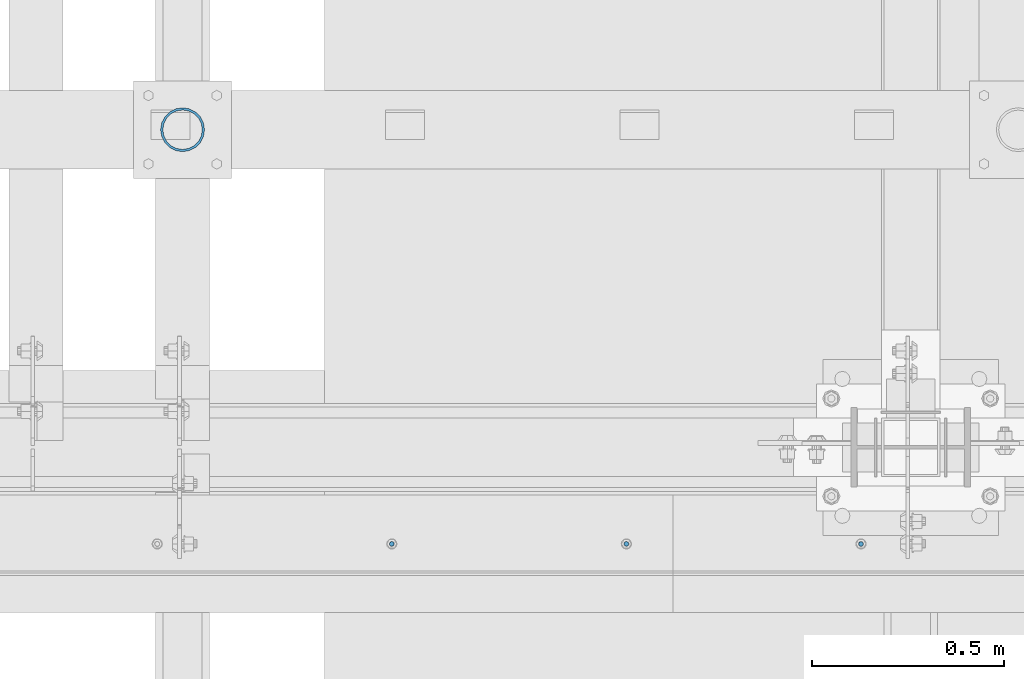
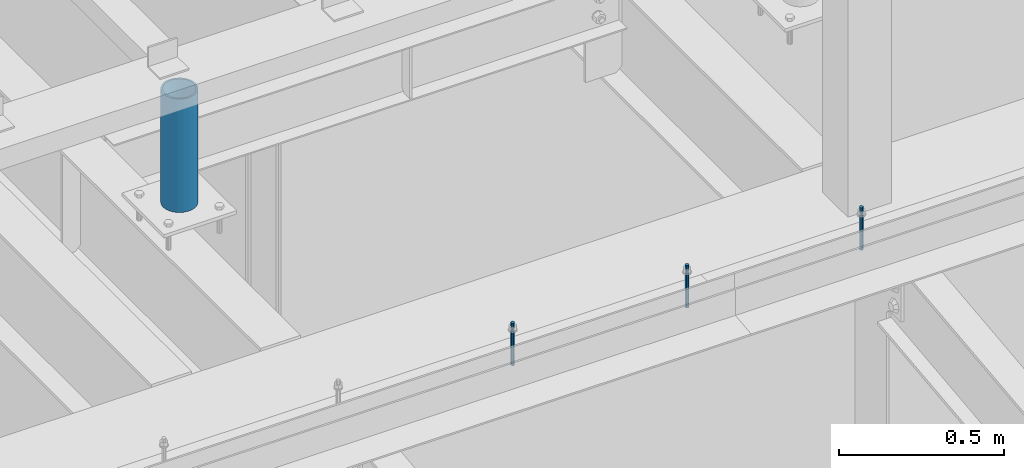
# One storey, part 537 of 1179: 4 columns, 2 elements without a shape of their own.
"""IFC2X3 building model written with IfcOpenShell, lengths in millimetres."""

from ifc_helpers import new_model, si_unit, frame, origin_with_axes, place, context, subcontext, project, spatial, faceted_brep, material, type_object, element, aggregate, save


model = new_model("IFC2X3")

# Units and contexts
model_context = context("Model", 3, precision=1e-05, world=origin_with_axes())
body_context = subcontext(model_context, "Body", "Model", "MODEL_VIEW")
ifc_project = project(units=[si_unit("LENGTHUNIT", "METRE", prefix="MILLI"), si_unit("AREAUNIT", "SQUARE_METRE"), si_unit("VOLUMEUNIT", "CUBIC_METRE"), si_unit("MASSUNIT", "GRAM", prefix="KILO"), si_unit("TIMEUNIT", "SECOND"), si_unit("PLANEANGLEUNIT", "RADIAN"), si_unit("SOLIDANGLEUNIT", "STERADIAN"), si_unit("THERMODYNAMICTEMPERATUREUNIT", "DEGREE_CELSIUS"), si_unit("LUMINOUSINTENSITYUNIT", "LUMEN")], contexts=[model_context])

# Site, building, storey
site_placement = place(None, origin_with_axes())
site = spatial("IfcSite", under=ifc_project, at=site_placement, CompositionType="ELEMENT")
building_placement = place(site_placement, origin_with_axes())
building = spatial("IfcBuilding", under=site, at=building_placement, Name="Undefined", CompositionType="ELEMENT")
storey_placement = place(building_placement, origin_with_axes())
storey = spatial("IfcBuildingStorey", under=building, at=storey_placement, Name="Undefined", CompositionType="ELEMENT", Elevation=0.0)

# Assembly, columns
assembly_1_placement = place(storey_placement, origin_with_axes())
assembly_1 = element("IfcElementAssembly", 1, at=assembly_1_placement, inside=storey, Name="BEAM", AssemblyPlace="NOTDEFINED", PredefinedType="RIGID_FRAME")
ifc_material_1 = material(Name="STEEL/A307")
column_type_1 = type_object("IfcColumnType", PredefinedType="NOTDEFINED")
column_1_placement = place(assembly_1_placement, frame((16329.8187504082, 34140.775, 13125.45), z_axis=(0.0, 1.0, 0.0), x_axis=(0.0, 0.0, 1.0)))
column_1 = element("IfcColumn", 2, at=column_1_placement, type_object=column_type_1, material=ifc_material_1, Name="THREADED ROD", context=body_context, shape_type="Brep", body=[
    faceted_brep([(0.0, -6.34999999999854, 0.0), (0.0, -4.49012806053361, -4.49012806053452), (157.162499999999, -4.49012806053361, -4.49012806053361), (157.162499999999, -6.34999999999854, 0.0), (0.0, 0.0, -6.34999999999991), (157.162499999999, 0.0, -6.34999999999854), (0.0, 4.49012806053361, -4.49012806053452), (157.162499999999, 4.49012806053361, -4.49012806053361), (0.0, 6.34999999999854, 0.0), (157.162499999999, 6.34999999999854, 0.0), (0.0, 4.49012806053361, 4.49012806053452), (157.162499999999, 4.49012806053361, 4.49012806053361), (0.0, 0.0, 6.34999999999991), (157.162499999999, 0.0, 6.34999999999854), (0.0, -4.49012806053361, 4.49012806053452), (157.162499999999, -4.49012806053361, 4.49012806053361)], [[[0, 1, 2, 3]], [[1, 4, 5, 2]], [[4, 6, 7, 5]], [[6, 8, 9, 7]], [[8, 10, 11, 9]], [[10, 12, 13, 11]], [[12, 14, 15, 13]], [[14, 0, 3, 15]], [[5, 7, 9, 11, 13, 15, 3, 2]], [[14, 12, 10, 8, 6, 4, 1, 0]]]),
])
column_2_placement = place(assembly_1_placement, frame((15720.2187504082, 34140.775, 13125.45), z_axis=(0.0, 1.0, 0.0), x_axis=(0.0, 0.0, 1.0)))
column_2 = element("IfcColumn", 3, at=column_2_placement, type_object=column_type_1, material=ifc_material_1, Name="THREADED ROD", context=body_context, shape_type="Brep", body=[
    faceted_brep([(0.0, -6.34999999999854, 0.0), (0.0, -4.49012806053361, -4.49012806053452), (157.162499999999, -4.49012806053361, -4.49012806053361), (157.162499999999, -6.34999999999854, 0.0), (0.0, 0.0, -6.34999999999991), (157.162499999999, 0.0, -6.34999999999854), (0.0, 4.49012806053361, -4.49012806053452), (157.162499999999, 4.49012806053361, -4.49012806053361), (0.0, 6.34999999999854, 0.0), (157.162499999999, 6.34999999999854, 0.0), (0.0, 4.49012806053361, 4.49012806053452), (157.162499999999, 4.49012806053361, 4.49012806053361), (0.0, 0.0, 6.34999999999991), (157.162499999999, 0.0, 6.34999999999854), (0.0, -4.49012806053361, 4.49012806053452), (157.162499999999, -4.49012806053361, 4.49012806053361)], [[[0, 1, 2, 3]], [[1, 4, 5, 2]], [[4, 6, 7, 5]], [[6, 8, 9, 7]], [[8, 10, 11, 9]], [[10, 12, 13, 11]], [[12, 14, 15, 13]], [[14, 0, 3, 15]], [[5, 7, 9, 11, 13, 15, 3, 2]], [[14, 12, 10, 8, 6, 4, 1, 0]]]),
])
column_3_placement = place(assembly_1_placement, frame((15110.6187504082, 34140.775, 13125.45), z_axis=(0.0, 1.0, 0.0), x_axis=(0.0, 0.0, 1.0)))
column_3 = element("IfcColumn", 4, at=column_3_placement, type_object=column_type_1, material=ifc_material_1, Name="THREADED ROD", context=body_context, shape_type="Brep", body=[
    faceted_brep([(0.0, -6.34999999999854, 0.0), (0.0, -4.49012806053361, -4.49012806053452), (157.162499999999, -4.49012806053361, -4.49012806053361), (157.162499999999, -6.34999999999854, 0.0), (0.0, 0.0, -6.34999999999991), (157.162499999999, 0.0, -6.34999999999854), (0.0, 4.49012806053361, -4.49012806053452), (157.162499999999, 4.49012806053361, -4.49012806053361), (0.0, 6.34999999999854, 0.0), (157.162499999999, 6.34999999999854, 0.0), (0.0, 4.49012806053361, 4.49012806053452), (157.162499999999, 4.49012806053361, 4.49012806053361), (0.0, 0.0, 6.34999999999991), (157.162499999999, 0.0, 6.34999999999854), (0.0, -4.49012806053361, 4.49012806053452), (157.162499999999, -4.49012806053361, 4.49012806053361)], [[[0, 1, 2, 3]], [[1, 4, 5, 2]], [[4, 6, 7, 5]], [[6, 8, 9, 7]], [[8, 10, 11, 9]], [[10, 12, 13, 11]], [[12, 14, 15, 13]], [[14, 0, 3, 15]], [[5, 7, 9, 11, 13, 15, 3, 2]], [[14, 12, 10, 8, 6, 4, 1, 0]]]),
])
aggregate(assembly_1, [column_1, column_2, column_3])

# Assembly, column
assembly_2_placement = place(storey_placement, origin_with_axes())
assembly_2 = element("IfcElementAssembly", 5, at=assembly_2_placement, inside=storey, Name="FRAME", AssemblyPlace="NOTDEFINED", PredefinedType="RIGID_FRAME")
ifc_material_2 = material()
column_type_2 = type_object("IfcColumnType", Name="PIPE4SCH40", PredefinedType="NOTDEFINED")
column_4_placement = place(assembly_2_placement, frame((14566.9, 35217.1, 13265.15), z_axis=(0.0, 1.0, 0.0), x_axis=(0.0, 0.0, 1.0)))
column_4 = element("IfcColumn", 6, at=column_4_placement, type_object=column_type_2, material=ifc_material_2, Name="COLUMN", ObjectType="PIPE4SCH40", context=body_context, shape_type="Brep", body=[
    faceted_brep([(0.0, -51.1301999999996, 0.0), (0.0, -48.6277098894752, 15.8001007257917), (419.099999999999, -48.6277098894752, 15.8001007257917), (419.099999999999, -51.1301999999996, 0.0), (0.0, -41.3652007257915, 30.0535775067619), (419.099999999999, -41.3652007257915, 30.0535775067619), (0.0, -30.0535775067656, 41.3652007257915), (419.099999999999, -30.0535775067656, 41.3652007257915), (0.0, -15.8001007257917, 48.6277098894716), (419.099999999999, -15.8001007257917, 48.6277098894716), (0.0, 0.0, 51.1301999999996), (419.099999999999, 0.0, 51.1301999999996), (0.0, 15.8001007257917, 48.6277098894716), (419.099999999999, 15.8001007257917, 48.6277098894716), (0.0, 30.0535775067656, 41.3652007257915), (419.099999999999, 30.0535775067656, 41.3652007257915), (0.0, 41.3652007257915, 30.0535775067619), (419.099999999999, 41.3652007257915, 30.0535775067619), (0.0, 48.6277098894752, 15.8001007257917), (419.099999999999, 48.6277098894752, 15.8001007257917), (0.0, 51.1301999999996, 0.0), (419.099999999999, 51.1301999999996, 0.0), (0.0, 48.6277098894752, -15.8001007257917), (419.099999999999, 48.6277098894752, -15.8001007257917), (0.0, 41.3652007257915, -30.0535775067619), (419.099999999999, 41.3652007257915, -30.0535775067619), (0.0, 30.0535775067656, -41.3652007257915), (419.099999999999, 30.0535775067656, -41.3652007257915), (0.0, 15.8001007257917, -48.6277098894716), (419.099999999999, 15.8001007257917, -48.6277098894716), (0.0, 0.0, -51.1301999999996), (419.099999999999, 0.0, -51.1301999999996), (0.0, -15.8001007257917, -48.6277098894716), (419.099999999999, -15.8001007257917, -48.6277098894716), (0.0, -30.0535775067656, -41.3652007257915), (419.099999999999, -30.0535775067656, -41.3652007257915), (0.0, -41.3652007257915, -30.0535775067619), (419.099999999999, -41.3652007257915, -30.0535775067619), (0.0, -48.6277098894752, -15.8001007257917), (419.099999999999, -48.6277098894752, -15.8001007257917), (0.0, -57.1500000000015, 0.0), (0.0, -54.3528799062697, -17.6603212285263), (419.099999999999, -54.3528799062697, -17.6603212285263), (419.099999999999, -57.1500000000015, 0.0), (0.0, -46.235321228527, -33.5919271685125), (419.099999999999, -46.235321228527, -33.5919271685125), (0.0, -33.5919271685161, -46.2353212285307), (419.099999999999, -33.5919271685161, -46.2353212285307), (0.0, -17.6603212285299, -54.3528799062697), (419.099999999999, -17.6603212285299, -54.3528799062697), (0.0, 0.0, -57.1500000000015), (419.099999999999, 0.0, -57.1500000000015), (0.0, 17.6603212285299, -54.3528799062697), (419.099999999999, 17.6603212285299, -54.3528799062697), (0.0, 33.5919271685161, -46.2353212285307), (419.099999999999, 33.5919271685161, -46.2353212285307), (0.0, 46.235321228527, -33.5919271685125), (419.099999999999, 46.235321228527, -33.5919271685125), (0.0, 54.3528799062697, -17.6603212285263), (419.099999999999, 54.3528799062697, -17.6603212285263), (0.0, 57.1500000000015, 0.0), (419.099999999999, 57.1500000000015, 0.0), (0.0, 54.3528799062697, 17.6603212285263), (419.099999999999, 54.3528799062697, 17.6603212285263), (0.0, 46.235321228527, 33.5919271685125), (419.099999999999, 46.235321228527, 33.5919271685125), (0.0, 33.5919271685161, 46.2353212285307), (419.099999999999, 33.5919271685161, 46.2353212285307), (0.0, 17.6603212285299, 54.3528799062697), (419.099999999999, 17.6603212285299, 54.3528799062697), (0.0, 0.0, 57.1500000000015), (419.099999999999, 0.0, 57.1500000000015), (0.0, -17.6603212285299, 54.3528799062697), (419.099999999999, -17.6603212285299, 54.3528799062697), (0.0, -33.5919271685161, 46.2353212285307), (419.099999999999, -33.5919271685161, 46.2353212285307), (0.0, -46.235321228527, 33.5919271685125), (419.099999999999, -46.235321228527, 33.5919271685125), (0.0, -54.3528799062697, 17.6603212285263), (419.099999999999, -54.3528799062697, 17.6603212285263)], [[[0, 1, 2, 3]], [[1, 4, 5, 2]], [[4, 6, 7, 5]], [[6, 8, 9, 7]], [[8, 10, 11, 9]], [[10, 12, 13, 11]], [[12, 14, 15, 13]], [[14, 16, 17, 15]], [[16, 18, 19, 17]], [[18, 20, 21, 19]], [[20, 22, 23, 21]], [[22, 24, 25, 23]], [[24, 26, 27, 25]], [[26, 28, 29, 27]], [[28, 30, 31, 29]], [[30, 32, 33, 31]], [[32, 34, 35, 33]], [[34, 36, 37, 35]], [[36, 38, 39, 37]], [[38, 0, 3, 39]], [[40, 41, 42, 43]], [[41, 44, 45, 42]], [[44, 46, 47, 45]], [[46, 48, 49, 47]], [[48, 50, 51, 49]], [[50, 52, 53, 51]], [[52, 54, 55, 53]], [[54, 56, 57, 55]], [[56, 58, 59, 57]], [[58, 60, 61, 59]], [[60, 62, 63, 61]], [[62, 64, 65, 63]], [[64, 66, 67, 65]], [[66, 68, 69, 67]], [[68, 70, 71, 69]], [[70, 72, 73, 71]], [[72, 74, 75, 73]], [[74, 76, 77, 75]], [[76, 78, 79, 77]], [[78, 40, 43, 79]], [[45, 47, 49, 51, 53, 55, 57, 59, 61, 63, 65, 67, 69, 71, 73, 75, 77, 79, 43, 42], [5, 7, 9, 11, 13, 15, 17, 19, 21, 23, 25, 27, 29, 31, 33, 35, 37, 39, 3, 2]], [[78, 76, 74, 72, 70, 68, 66, 64, 62, 60, 58, 56, 54, 52, 50, 48, 46, 44, 41, 40], [38, 36, 34, 32, 30, 28, 26, 24, 22, 20, 18, 16, 14, 12, 10, 8, 6, 4, 1, 0]]]),
])
aggregate(assembly_2, [column_4])

save(model, "model.ifc")
